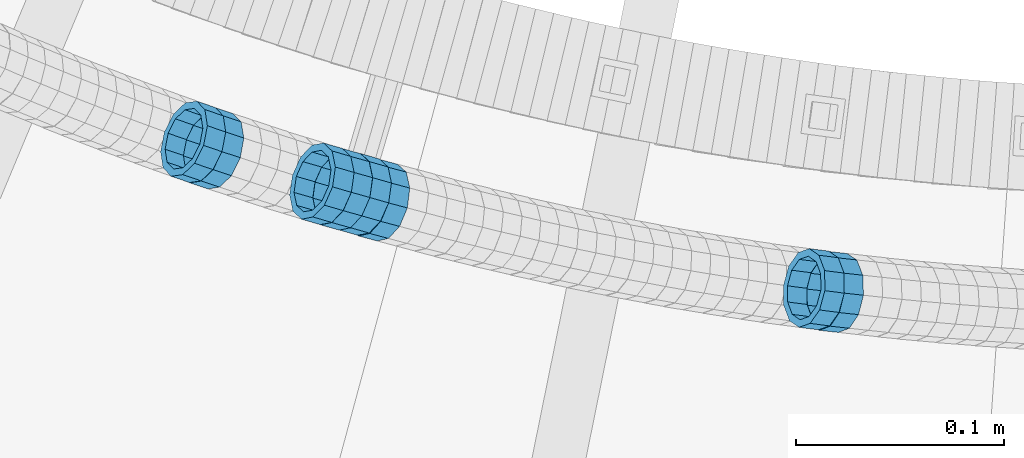
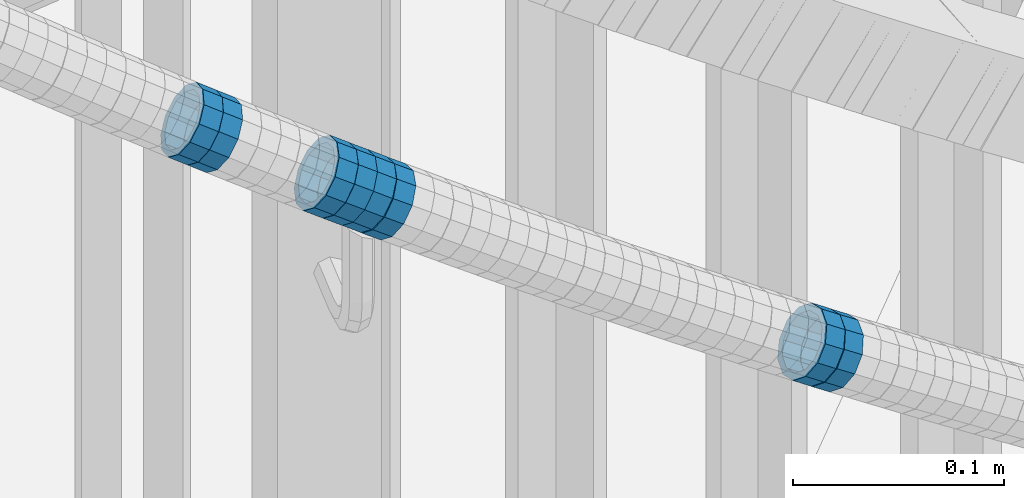
# One storey, part 688 of 975: 8 members.
"""IFC2X3 building model written with IfcOpenShell, lengths in millimetres."""

from ifc_helpers import new_model, si_unit, frame, origin_with_axes, place, context, subcontext, project, spatial, faceted_brep, material, type_object, element, save


model = new_model("IFC2X3")

# Units and contexts
model_context = context("Model", 3, precision=1e-05, world=origin_with_axes())
body_context = subcontext(model_context, "Body", "Model", "MODEL_VIEW")
ifc_project = project(units=[si_unit("LENGTHUNIT", "METRE", prefix="MILLI"), si_unit("AREAUNIT", "SQUARE_METRE"), si_unit("VOLUMEUNIT", "CUBIC_METRE"), si_unit("MASSUNIT", "GRAM", prefix="KILO"), si_unit("TIMEUNIT", "SECOND"), si_unit("PLANEANGLEUNIT", "RADIAN"), si_unit("SOLIDANGLEUNIT", "STERADIAN"), si_unit("THERMODYNAMICTEMPERATUREUNIT", "DEGREE_CELSIUS"), si_unit("LUMINOUSINTENSITYUNIT", "LUMEN")], contexts=[model_context])

# Site, building, storey
site_placement = place(None, origin_with_axes())
site = spatial("IfcSite", under=ifc_project, at=site_placement, CompositionType="ELEMENT")
building_placement = place(site_placement, origin_with_axes())
building = spatial("IfcBuilding", under=site, at=building_placement, Name="Undefined", CompositionType="ELEMENT")
storey_placement = place(building_placement, origin_with_axes())
storey = spatial("IfcBuildingStorey", under=building, at=storey_placement, Name="Undefined", CompositionType="ELEMENT", Elevation=0.0)

# Members
ifc_material = material()
member_type = type_object("IfcMemberType", PredefinedType="NOTDEFINED")
member_1_placement = place(storey_placement, frame((34258.5164340381, 2002.63154159642, 4505.87445303745), z_axis=(-0.312988116355664, -0.949757042100838, 1.91695107787382e-10), x_axis=(-0.808941078191672, 0.266582855063186, 0.523973199124206)))
element("IfcMember", 1, at=member_1_placement, inside=storey, type_object=member_type, material=ifc_material, Name="WALL", context=body_context, shape_type="Brep", body=[
    faceted_brep([(-2.1246523829177e-07, -15.367000000002, 0.0), (-1.83998054126278e-07, -13.3082123799541, 7.68350000000009), (10.8784190028109, -13.3082123799541, 7.68349999999555), (10.8784190028309, -15.3669999999929, 2.5465851649642e-11), (-1.06232619145885e-07, -7.68349999999919, 13.3082123799559), (10.8784190027873, -7.68350000000464, 13.308212379925), (-3.63797880709171e-12, 3.63797880709171e-12, 15.3670000000002), (10.8784190027782, -9.09494701772928e-12, 15.3669999999584), (1.06225343188271e-07, 7.68350000000646, 13.3082123799559), (10.8784190027691, 7.68349999998645, 13.3082123798995), (1.8399441614747e-07, 13.308212379965, 7.68350000000009), (10.8784190027764, 13.3082123799431, 7.68349999995553), (2.12461600312963e-07, 15.3670000000093, 0.0), (10.8784190027891, 15.3669999999929, -2.91038304567337e-11), (1.8399441614747e-07, 13.308212379965, -7.68350000000009), (10.8784190028055, 13.3082123799541, -7.68350000000646), (1.06225343188271e-07, 7.68350000000646, -13.3082123799559), (10.8784190028236, 7.68350000000464, -13.3082123799431), (-3.63797880709171e-12, 3.63797880709171e-12, -15.3670000000002), (10.87841900284, 1.2732925824821e-11, -15.366999999962), (-1.06232619145885e-07, -7.68349999999919, -13.3082123799559), (10.8784190028437, -7.68349999998463, -13.308212379914), (-1.83998054126278e-07, -13.3082123799541, -7.68350000000009), (10.8784190028437, -13.3082123799413, -7.68349999996281), (-2.63386027654633e-07, -19.0500000000029, 0.0), (-2.28097633225843e-07, -16.4977839420972, -9.52499999999964), (10.8784190028491, -16.4977839420771, -9.52499999995416), (10.8784190028346, -19.0499999999902, 2.91038304567337e-11), (-1.31691194837913e-07, -9.52500000000146, -16.4977839420935), (10.8784190028582, -9.52499999998145, -16.497783942039), (-3.63797880709171e-12, 3.63797880709171e-12, -19.0500000000002), (10.8784190028473, 1.63709046319127e-11, -19.0499999999556), (1.31687556859106e-07, 9.52500000000509, -16.4977839420935), (10.8784190028291, 9.52500000000691, -16.4977839420753), (2.28097633225843e-07, 16.4977839421044, -9.52499999999964), (10.8784190028073, 16.4977839420917, -9.52500000000509), (2.63382389675826e-07, 19.0500000000138, 0.0), (10.8784190027836, 19.0499999999884, -4.00177668780088e-11), (2.28097633225843e-07, 16.4977839421044, 9.52499999999964), (10.8784190027654, 16.4977839420771, 9.52499999994325), (1.31687556859106e-07, 9.52500000000509, 16.4977839420935), (10.8784190027636, 9.52499999998327, 16.4977839420317), (-3.63797880709171e-12, 3.63797880709171e-12, 19.0500000000002), (10.8784190027709, -1.63709046319127e-11, 19.0499999999447), (-1.31691194837913e-07, -9.52500000000146, 16.4977839420935), (10.8784190027854, -9.52500000000691, 16.4977839420644), (-2.28097633225843e-07, -16.4977839420972, 9.52499999999964), (10.8784190028091, -16.4977839420899, 9.52500000000146)], [[[0, 1, 2, 3]], [[1, 4, 5, 2]], [[4, 6, 7, 5]], [[6, 8, 9, 7]], [[8, 10, 11, 9]], [[10, 12, 13, 11]], [[12, 14, 15, 13]], [[14, 16, 17, 15]], [[16, 18, 19, 17]], [[18, 20, 21, 19]], [[20, 22, 23, 21]], [[22, 0, 3, 23]], [[24, 25, 26, 27]], [[25, 28, 29, 26]], [[28, 30, 31, 29]], [[30, 32, 33, 31]], [[32, 34, 35, 33]], [[34, 36, 37, 35]], [[36, 38, 39, 37]], [[38, 40, 41, 39]], [[40, 42, 43, 41]], [[42, 44, 45, 43]], [[44, 46, 47, 45]], [[46, 24, 27, 47]], [[29, 31, 33, 35, 37, 39, 41, 43, 45, 47, 27, 26], [5, 7, 9, 11, 13, 15, 17, 19, 21, 23, 3, 2]], [[46, 44, 42, 40, 38, 36, 34, 32, 30, 28, 25, 24], [22, 20, 18, 16, 14, 12, 10, 8, 6, 4, 1, 0]]]),
])
member_2_placement = place(storey_placement, frame((34249.7723069922, 2005.62022331465, 4511.55922879623), z_axis=(-0.322673927941658, -0.946510188126204, -5.88215698371641e-11), x_axis=(-0.806932045135231, 0.275090470046072, 0.522671893087532)))
element("IfcMember", 2, at=member_2_placement, inside=storey, type_object=member_type, material=ifc_material, Name="WALL", context=body_context, shape_type="Brep", body=[
    faceted_brep([(-2.1246523829177e-07, -15.367000000002, 0.0), (-1.83998054126278e-07, -13.3082123799541, 7.68350000000009), (10.9055031979988, -13.3082123799322, 7.68349999999873), (10.9055031979988, -15.3669999999729, -1.81898940354586e-12), (-1.06232619145885e-07, -7.68349999999919, 13.3082123799559), (10.9055031979842, -7.683499999981, 13.3082123799552), (-3.63797880709171e-12, 3.63797880709171e-12, 15.3670000000002), (10.9055031979697, 7.27595761418343e-12, 15.3670000000002), (1.06225343188271e-07, 7.68350000000646, 13.3082123799559), (10.9055031979478, 7.68349999999191, 13.3082123799561), (1.8399441614747e-07, 13.308212379965, 7.68350000000009), (10.9055031979333, 13.3082123799395, 7.68350000000078), (2.12461600312963e-07, 15.3670000000093, 0.0), (10.9055031979187, 15.3669999999802, 4.54747350886464e-13), (1.8399441614747e-07, 13.308212379965, -7.68350000000009), (10.9055031979187, 13.3082123799395, -7.68350000000009), (1.06225343188271e-07, 7.68350000000646, -13.3082123799559), (10.9055031979296, 7.68349999999191, -13.3082123799561), (-3.63797880709171e-12, 3.63797880709171e-12, -15.3670000000002), (10.9055031979478, 3.63797880709171e-12, -15.3670000000013), (-1.06232619145885e-07, -7.68349999999919, -13.3082123799559), (10.9055031979697, -7.683499999981, -13.3082123799575), (-1.83998054126278e-07, -13.3082123799541, -7.68350000000009), (10.9055031979842, -13.3082123799286, -7.68350000000214), (-2.63386027654633e-07, -19.0500000000029, 0.0), (-2.28097633225843e-07, -16.4977839420972, -9.52499999999964), (10.9055031979879, -16.4977839420681, -9.52500000000214), (10.9055031980097, -19.0499999999629, -2.04636307898909e-12), (-1.31691194837913e-07, -9.52500000000146, -16.4977839420935), (10.9055031979624, -9.52499999998327, -16.4977839420956), (-3.63797880709171e-12, 3.63797880709171e-12, -19.0500000000002), (10.9055031979406, 3.63797880709171e-12, -19.0500000000015), (1.31687556859106e-07, 9.52500000000509, -16.4977839420935), (10.9055031979151, 9.5249999999869, -16.4977839420942), (2.28097633225843e-07, 16.4977839421044, -9.52499999999964), (10.9055031979115, 16.4977839420717, -9.52499999999986), (2.63382389675826e-07, 19.0500000000138, 0.0), (10.9055031979115, 19.0499999999774, 6.82121026329696e-13), (2.28097633225843e-07, 16.4977839421044, 9.52499999999964), (10.9055031979296, 16.4977839420753, 9.52500000000123), (1.31687556859106e-07, 9.52500000000509, 16.4977839420935), (10.9055031979515, 9.52499999999054, 16.4977839420942), (-3.63797880709171e-12, 3.63797880709171e-12, 19.0500000000002), (10.9055031979733, 7.27595761418343e-12, 19.0500000000004), (-1.31691194837913e-07, -9.52500000000146, 16.4977839420935), (10.9055031979988, -9.52499999997599, 16.4977839420933), (-2.28097633225843e-07, -16.4977839420972, 9.52499999999964), (10.905503198006, -16.4977839420644, 9.52499999999873)], [[[0, 1, 2, 3]], [[1, 4, 5, 2]], [[4, 6, 7, 5]], [[6, 8, 9, 7]], [[8, 10, 11, 9]], [[10, 12, 13, 11]], [[12, 14, 15, 13]], [[14, 16, 17, 15]], [[16, 18, 19, 17]], [[18, 20, 21, 19]], [[20, 22, 23, 21]], [[22, 0, 3, 23]], [[24, 25, 26, 27]], [[25, 28, 29, 26]], [[28, 30, 31, 29]], [[30, 32, 33, 31]], [[32, 34, 35, 33]], [[34, 36, 37, 35]], [[36, 38, 39, 37]], [[38, 40, 41, 39]], [[40, 42, 43, 41]], [[42, 44, 45, 43]], [[44, 46, 47, 45]], [[46, 24, 27, 47]], [[29, 31, 33, 35, 37, 39, 41, 43, 45, 47, 27, 26], [5, 7, 9, 11, 13, 15, 17, 19, 21, 23, 3, 2]], [[46, 44, 42, 40, 38, 36, 34, 32, 30, 28, 25, 24], [22, 20, 18, 16, 14, 12, 10, 8, 6, 4, 1, 0]]]),
])
member_3_placement = place(storey_placement, frame((34557.1645562191, 1934.58696290878, 4316.57991200939), z_axis=(-0.108059180815137, -0.994144463064379, -1.17480340122711e-10), x_axis=(-0.846462505067043, 0.0920067940072997, 0.524438726041588)))
element("IfcMember", 3, at=member_3_placement, inside=storey, type_object=member_type, material=ifc_material, Name="WALL", context=body_context, shape_type="Brep", body=[
    faceted_brep([(-2.1246523829177e-07, -15.367000000002, 0.0), (-1.83998054126278e-07, -13.3082123799541, 7.68350000000009), (10.8747413762467, -13.3082123799468, 7.68349999999737), (10.8747413762612, -15.3669999999911, -4.54747350886464e-12), (-1.06232619145885e-07, -7.68349999999919, 13.3082123799559), (10.8747413762321, -7.68350000000282, 13.3082123799559), (-3.63797880709171e-12, 3.63797880709171e-12, 15.3670000000002), (10.8747413762212, -7.27595761418343e-12, 15.3670000000029), (1.06225343188271e-07, 7.68350000000646, 13.3082123799559), (10.8747413762139, 7.68349999998827, 13.3082123799586), (1.8399441614747e-07, 13.308212379965, 7.68350000000009), (10.8747413762212, 13.3082123799504, 7.683500000001), (2.12461600312963e-07, 15.3670000000093, 0.0), (10.8747413762285, 15.3669999999984, 9.09494701772928e-13), (1.8399441614747e-07, 13.308212379965, -7.68350000000009), (10.8747413762394, 13.3082123799613, -7.683500000001), (1.06225343188271e-07, 7.68350000000646, -13.3082123799559), (10.874741376254, 7.68350000001374, -13.3082123799604), (-3.63797880709171e-12, 3.63797880709171e-12, -15.3670000000002), (10.8747413762685, 1.81898940354586e-11, -15.3670000000056), (-1.06232619145885e-07, -7.68349999999919, -13.3082123799559), (10.8747413762758, -7.683499999981, -13.3082123799632), (-1.83998054126278e-07, -13.3082123799541, -7.68350000000009), (10.8747413762721, -13.3082123799359, -7.68350000000737), (-2.63386027654633e-07, -19.0500000000029, 0.0), (-2.28097633225843e-07, -16.4977839420972, -9.52499999999964), (10.8747413762867, -16.4977839420681, -9.52500000000873), (10.8747413762685, -19.0499999999847, -6.3664629124105e-12), (-1.31691194837913e-07, -9.52500000000146, -16.4977839420935), (10.8747413762831, -9.52499999997599, -16.4977839421026), (-3.63797880709171e-12, 3.63797880709171e-12, -19.0500000000002), (10.8747413762758, 2.5465851649642e-11, -19.0500000000084), (1.31687556859106e-07, 9.52500000000509, -16.4977839420935), (10.8747413762612, 9.52500000001601, -16.497783942099), (2.28097633225843e-07, 16.4977839421044, -9.52499999999964), (10.8747413762394, 16.4977839421008, -9.52500000000146), (2.63382389675826e-07, 19.0500000000138, 0.0), (10.8747413762248, 19.0499999999956, 0.0), (2.28097633225843e-07, 16.4977839421044, 9.52499999999964), (10.8747413762103, 16.497783942079, 9.52500000000418), (1.31687556859106e-07, 9.52500000000509, 16.4977839420935), (10.8747413762067, 9.52499999998327, 16.4977839420981), (-3.63797880709171e-12, 3.63797880709171e-12, 19.0500000000002), (10.8747413762212, -1.09139364212751e-11, 19.0500000000029), (-1.31691194837913e-07, -9.52500000000146, 16.4977839420935), (10.8747413762358, -9.52500000000146, 16.4977839420944), (-2.28097633225843e-07, -16.4977839420972, 9.52499999999964), (10.874741376254, -16.4977839420862, 9.524999999996)], [[[0, 1, 2, 3]], [[1, 4, 5, 2]], [[4, 6, 7, 5]], [[6, 8, 9, 7]], [[8, 10, 11, 9]], [[10, 12, 13, 11]], [[12, 14, 15, 13]], [[14, 16, 17, 15]], [[16, 18, 19, 17]], [[18, 20, 21, 19]], [[20, 22, 23, 21]], [[22, 0, 3, 23]], [[24, 25, 26, 27]], [[25, 28, 29, 26]], [[28, 30, 31, 29]], [[30, 32, 33, 31]], [[32, 34, 35, 33]], [[34, 36, 37, 35]], [[36, 38, 39, 37]], [[38, 40, 41, 39]], [[40, 42, 43, 41]], [[42, 44, 45, 43]], [[44, 46, 47, 45]], [[46, 24, 27, 47]], [[29, 31, 33, 35, 37, 39, 41, 43, 45, 47, 27, 26], [5, 7, 9, 11, 13, 15, 17, 19, 21, 23, 3, 2]], [[46, 44, 42, 40, 38, 36, 34, 32, 30, 28, 25, 24], [22, 20, 18, 16, 14, 12, 10, 8, 6, 4, 1, 0]]]),
])
member_4_placement = place(storey_placement, frame((34547.9580375468, 1935.78978836989, 4322.29868348133), z_axis=(-0.127971337933879, -0.99177786659484, -8.49195203045383e-12), x_axis=(-0.843470193525273, 0.108834863938749, 0.526035174704005)))
element("IfcMember", 4, at=member_4_placement, inside=storey, type_object=member_type, material=ifc_material, Name="WALL", context=body_context, shape_type="Brep", body=[
    faceted_brep([(-2.1246523829177e-07, -15.367000000002, 0.0), (-1.83998054126278e-07, -13.3082123799541, 7.68350000000009), (11.0295058819465, -13.3082123799577, 7.68350000000055), (11.0295058819393, -15.3670000000056, 0.0), (-1.06232619145885e-07, -7.68349999999919, 13.3082123799559), (11.0295058819502, -7.68350000000282, 13.3082123799563), (-3.63797880709171e-12, 3.63797880709171e-12, 15.3670000000002), (11.0295058819574, 0.0, 15.3670000000006), (1.06225343188271e-07, 7.68350000000646, 13.3082123799559), (11.0295058819647, 7.68350000000646, 13.3082123799559), (1.8399441614747e-07, 13.308212379965, 7.68350000000009), (11.0295058819756, 13.308212379965, 7.68349999999919), (2.12461600312963e-07, 15.3670000000093, 0.0), (11.029505881972, 15.3670000000056, -1.36424205265939e-12), (1.8399441614747e-07, 13.308212379965, -7.68350000000009), (11.0295058819684, 13.3082123799613, -7.683500000001), (1.06225343188271e-07, 7.68350000000646, -13.3082123799559), (11.0295058819574, 7.68350000000282, -13.3082123799563), (-3.63797880709171e-12, 3.63797880709171e-12, -15.3670000000002), (11.0295058819502, 0.0, -15.3670000000011), (-1.06232619145885e-07, -7.68349999999919, -13.3082123799559), (11.0295058819465, -7.68350000000282, -13.3082123799559), (-1.83998054126278e-07, -13.3082123799541, -7.68350000000009), (11.0295058819393, -13.3082123799613, -7.68350000000009), (-2.63386027654633e-07, -19.0500000000029, 0.0), (-2.28097633225843e-07, -16.4977839420972, -9.52499999999964), (11.0295058819356, -16.4977839421008, -9.52499999999964), (11.0295058819356, -19.0500000000102, 9.09494701772928e-13), (-1.31691194837913e-07, -9.52500000000146, -16.4977839420935), (11.0295058819393, -9.52500000000146, -16.497783942094), (-3.63797880709171e-12, 3.63797880709171e-12, -19.0500000000002), (11.0295058819429, 0.0, -19.0500000000015), (1.31687556859106e-07, 9.52500000000509, -16.4977839420935), (11.0295058819574, 9.52500000000146, -16.4977839420949), (2.28097633225843e-07, 16.4977839421044, -9.52499999999964), (11.029505881972, 16.4977839421044, -9.52500000000191), (2.63382389675826e-07, 19.0500000000138, 0.0), (11.0295058819793, 19.0500000000102, -4.54747350886464e-13), (2.28097633225843e-07, 16.4977839421044, 9.52499999999964), (11.0295058819793, 16.4977839421044, 9.52499999999918), (1.31687556859106e-07, 9.52500000000509, 16.4977839420935), (11.029505881972, 9.52500000000509, 16.4977839420935), (-3.63797880709171e-12, 3.63797880709171e-12, 19.0500000000002), (11.0295058819611, 0.0, 19.0500000000011), (-1.31691194837913e-07, -9.52500000000146, 16.4977839420935), (11.0295058819465, -9.52500000000509, 16.4977839420949), (-2.28097633225843e-07, -16.4977839420972, 9.52499999999964), (11.0295058819393, -16.4977839421008, 9.52500000000055)], [[[0, 1, 2, 3]], [[1, 4, 5, 2]], [[4, 6, 7, 5]], [[6, 8, 9, 7]], [[8, 10, 11, 9]], [[10, 12, 13, 11]], [[12, 14, 15, 13]], [[14, 16, 17, 15]], [[16, 18, 19, 17]], [[18, 20, 21, 19]], [[20, 22, 23, 21]], [[22, 0, 3, 23]], [[24, 25, 26, 27]], [[25, 28, 29, 26]], [[28, 30, 31, 29]], [[30, 32, 33, 31]], [[32, 34, 35, 33]], [[34, 36, 37, 35]], [[36, 38, 39, 37]], [[38, 40, 41, 39]], [[40, 42, 43, 41]], [[42, 44, 45, 43]], [[44, 46, 47, 45]], [[46, 24, 27, 47]], [[29, 31, 33, 35, 37, 39, 41, 43, 45, 47, 27, 26], [5, 7, 9, 11, 13, 15, 17, 19, 21, 23, 3, 2]], [[46, 44, 42, 40, 38, 36, 34, 32, 30, 28, 25, 24], [22, 20, 18, 16, 14, 12, 10, 8, 6, 4, 1, 0]]]),
])
member_5_placement = place(storey_placement, frame((34338.5888265773, 1977.96946803606, 4454.15104049631), z_axis=(-0.257662650594451, -0.966234939592148, -1.78564732777886e-10), x_axis=(-0.824163383850657, 0.219776901960162, 0.521970142905347)))
element("IfcMember", 5, at=member_5_placement, inside=storey, type_object=member_type, material=ifc_material, Name="WALL", context=body_context, shape_type="Brep", body=[
    faceted_brep([(-2.1246523829177e-07, -15.367000000002, 0.0), (-1.83998054126278e-07, -13.3082123799541, 7.68350000000009), (10.9242848735521, -13.3082123800159, 7.68350000000919), (10.9242848735703, -15.3670000000457, 6.82121026329696e-12), (-1.06232619145885e-07, -7.68349999999919, 13.3082123799559), (10.9242848735521, -7.68350000005739, 13.3082123799652), (-3.63797880709171e-12, 3.63797880709171e-12, 15.3670000000002), (10.924284873563, -4.72937244921923e-11, 15.3670000000088), (1.06225343188271e-07, 7.68350000000646, 13.3082123799559), (10.9242848735885, 7.68349999997008, 13.308212379962), (1.8399441614747e-07, 13.308212379965, 7.68350000000009), (10.9242848736176, 13.3082123799468, 7.68350000000328), (2.12461600312963e-07, 15.3670000000093, 0.0), (10.9242848736394, 15.3670000000093, 0.0), (1.8399441614747e-07, 13.308212379965, -7.68350000000009), (10.9242848736576, 13.3082123799795, -7.6835000000026), (1.06225343188271e-07, 7.68350000000646, -13.3082123799559), (10.9242848736576, 7.68350000002465, -13.3082123799584), (-3.63797880709171e-12, 3.63797880709171e-12, -15.3670000000002), (10.9242848736467, 1.45519152283669e-11, -15.3670000000025), (-1.06232619145885e-07, -7.68349999999919, -13.3082123799559), (10.9242848736212, -7.68350000000282, -13.3082123799552), (-1.83998054126278e-07, -13.3082123799541, -7.68350000000009), (10.9242848735958, -13.3082123799832, -7.68349999999646), (-2.63386027654633e-07, -19.0500000000029, 0.0), (-2.28097633225843e-07, -16.4977839420972, -9.52499999999964), (10.9242848735885, -16.4977839421226, -9.52499999999577), (10.9242848735557, -19.0500000000575, 8.18545231595635e-12), (-1.31691194837913e-07, -9.52500000000146, -16.4977839420935), (10.9242848736249, -9.52500000000146, -16.4977839420942), (-3.63797880709171e-12, 3.63797880709171e-12, -19.0500000000002), (10.924284873654, 2.18278728425503e-11, -19.0500000000038), (1.31687556859106e-07, 9.52500000000509, -16.4977839420935), (10.9242848736758, 9.52500000003783, -16.4977839420985), (2.28097633225843e-07, 16.4977839421044, -9.52499999999964), (10.9242848736758, 16.4977839421299, -9.52500000000418), (2.63382389675826e-07, 19.0500000000138, 0.0), (10.9242848736503, 19.0500000000211, -1.36424205265939e-12), (2.28097633225843e-07, 16.4977839421044, 9.52499999999964), (10.9242848736249, 16.4977839420899, 9.52500000000259), (1.31687556859106e-07, 9.52500000000509, 16.4977839420935), (10.9242848735885, 9.52499999996508, 16.4977839421008), (-3.63797880709171e-12, 3.63797880709171e-12, 19.0500000000002), (10.9242848735594, -5.82076609134674e-11, 19.0500000000104), (-1.31691194837913e-07, -9.52500000000146, 16.4977839420935), (10.9242848735375, -9.52500000007058, 16.4977839421056), (-2.28097633225843e-07, -16.4977839420972, 9.52499999999964), (10.9242848735412, -16.4977839421626, 9.52500000001078)], [[[0, 1, 2, 3]], [[1, 4, 5, 2]], [[4, 6, 7, 5]], [[6, 8, 9, 7]], [[8, 10, 11, 9]], [[10, 12, 13, 11]], [[12, 14, 15, 13]], [[14, 16, 17, 15]], [[16, 18, 19, 17]], [[18, 20, 21, 19]], [[20, 22, 23, 21]], [[22, 0, 3, 23]], [[24, 25, 26, 27]], [[25, 28, 29, 26]], [[28, 30, 31, 29]], [[30, 32, 33, 31]], [[32, 34, 35, 33]], [[34, 36, 37, 35]], [[36, 38, 39, 37]], [[38, 40, 41, 39]], [[40, 42, 43, 41]], [[42, 44, 45, 43]], [[44, 46, 47, 45]], [[46, 24, 27, 47]], [[29, 31, 33, 35, 37, 39, 41, 43, 45, 47, 27, 26], [5, 7, 9, 11, 13, 15, 17, 19, 21, 23, 3, 2]], [[46, 44, 42, 40, 38, 36, 34, 32, 30, 28, 25, 24], [22, 20, 18, 16, 14, 12, 10, 8, 6, 4, 1, 0]]]),
])
member_6_placement = place(storey_placement, frame((34329.5625874627, 1980.59055460896, 4459.90302386072), z_axis=(-0.277539653203669, -0.960714182730529, 1.67447979038116e-10), x_axis=(-0.81683279512389, 0.235973919035816, 0.526403357079884)))
element("IfcMember", 6, at=member_6_placement, inside=storey, type_object=member_type, material=ifc_material, Name="WALL", context=body_context, shape_type="Brep", body=[
    faceted_brep([(-2.1246523829177e-07, -15.367000000002, 0.0), (-1.83998054126278e-07, -13.3082123799541, 7.68350000000009), (11.0181668166479, -13.3082123799941, 7.68349999998463), (11.0181668166588, -15.3670000000275, -1.09139364212751e-11), (-1.06232619145885e-07, -7.68349999999919, 13.3082123799559), (11.0181668166369, -7.6835000000392, 13.3082123799377), (-3.63797880709171e-12, 3.63797880709171e-12, 15.3670000000002), (11.0181668166297, -4.00177668780088e-11, 15.3669999999784), (1.06225343188271e-07, 7.68350000000646, 13.3082123799559), (11.0181668166333, 7.68349999996644, 13.3082123799359), (1.8399441614747e-07, 13.308212379965, 7.68350000000009), (11.0181668166442, 13.3082123799286, 7.68349999998463), (2.12461600312963e-07, 15.3670000000093, 0.0), (11.0181668166588, 15.3669999999838, -9.09494701772928e-12), (1.8399441614747e-07, 13.308212379965, -7.68350000000009), (11.0181668166697, 13.3082123799504, -7.68350000000464), (1.06225343188271e-07, 7.68350000000646, -13.3082123799559), (11.0181668166806, 7.68349999999555, -13.3082123799577), (-3.63797880709171e-12, 3.63797880709171e-12, -15.3670000000002), (11.0181668166842, -7.27595761418343e-12, -15.367000000002), (-1.06232619145885e-07, -7.68349999999919, -13.3082123799559), (11.018166816677, -7.68350000001374, -13.3082123799595), (-1.83998054126278e-07, -13.3082123799541, -7.68350000000009), (11.0181668166661, -13.3082123799795, -7.68350000000646), (-2.63386027654633e-07, -19.0500000000029, 0.0), (-2.28097633225843e-07, -16.4977839420972, -9.52499999999964), (11.0181668166733, -16.4977839421153, -9.52500000000509), (11.0181668166588, -19.0500000000284, -1.2732925824821e-11), (-1.31691194837913e-07, -9.52500000000146, -16.4977839420935), (11.0181668166842, -9.52500000001237, -16.4977839420953), (-3.63797880709171e-12, 3.63797880709171e-12, -19.0500000000002), (11.0181668166915, -3.63797880709171e-12, -19.0500000000011), (1.31687556859106e-07, 9.52500000000509, -16.4977839420935), (11.0181668166879, 9.52499999999782, -16.4977839420935), (2.28097633225843e-07, 16.4977839421044, -9.52499999999964), (11.018166816677, 16.4977839420862, -9.52500000000691), (2.63382389675826e-07, 19.0500000000138, 0.0), (11.0181668166624, 19.0499999999884, -1.09139364212751e-11), (2.28097633225843e-07, 16.4977839421044, 9.52499999999964), (11.0181668166406, 16.4977839420644, 9.52499999998145), (1.31687556859106e-07, 9.52500000000509, 16.4977839420935), (11.0181668166297, 9.52499999996508, 16.4977839420717), (-3.63797880709171e-12, 3.63797880709171e-12, 19.0500000000002), (11.0181668166224, -4.00177668780088e-11, 19.0499999999738), (-1.31691194837913e-07, -9.52500000000146, 16.4977839420935), (11.0181668166297, -9.52500000004511, 16.4977839420735), (-2.28097633225843e-07, -16.4977839420972, 9.52499999999964), (11.0181668166406, -16.4977839421335, 9.52499999998327)], [[[0, 1, 2, 3]], [[1, 4, 5, 2]], [[4, 6, 7, 5]], [[6, 8, 9, 7]], [[8, 10, 11, 9]], [[10, 12, 13, 11]], [[12, 14, 15, 13]], [[14, 16, 17, 15]], [[16, 18, 19, 17]], [[18, 20, 21, 19]], [[20, 22, 23, 21]], [[22, 0, 3, 23]], [[24, 25, 26, 27]], [[25, 28, 29, 26]], [[28, 30, 31, 29]], [[30, 32, 33, 31]], [[32, 34, 35, 33]], [[34, 36, 37, 35]], [[36, 38, 39, 37]], [[38, 40, 41, 39]], [[40, 42, 43, 41]], [[42, 44, 45, 43]], [[44, 46, 47, 45]], [[46, 24, 27, 47]], [[29, 31, 33, 35, 37, 39, 41, 43, 45, 47, 27, 26], [5, 7, 9, 11, 13, 15, 17, 19, 21, 23, 3, 2]], [[46, 44, 42, 40, 38, 36, 34, 32, 30, 28, 25, 24], [22, 20, 18, 16, 14, 12, 10, 8, 6, 4, 1, 0]]]),
])
member_7_placement = place(storey_placement, frame((34320.5709780693, 1983.11122170574, 4465.68460807061), z_axis=(-0.270432301548208, -0.962738993850015, -2.43180693360045e-10), x_axis=(-0.819485047910005, 0.230192428974721, 0.524838738942406)))
element("IfcMember", 7, at=member_7_placement, inside=storey, type_object=member_type, material=ifc_material, Name="WALL", context=body_context, shape_type="Brep", body=[
    faceted_brep([(-2.1246523829177e-07, -15.367000000002, 0.0), (-1.83998054126278e-07, -13.3082123799541, 7.68350000000009), (10.8613995415399, -13.3082123799322, 7.68349999999191), (10.8613995415435, -15.3669999999729, -8.18545231595635e-12), (-1.06232619145885e-07, -7.68349999999919, 13.3082123799559), (10.8613995415217, -7.683499999981, 13.3082123799504), (-3.63797880709171e-12, 3.63797880709171e-12, 15.3670000000002), (10.8613995415071, 3.63797880709171e-12, 15.3669999999984), (1.06225343188271e-07, 7.68350000000646, 13.3082123799559), (10.861399541478, 7.68349999998463, 13.3082123799586), (1.8399441614747e-07, 13.308212379965, 7.68350000000009), (10.8613995414671, 13.3082123799322, 7.68350000000555), (2.12461600312963e-07, 15.3670000000093, 0.0), (10.8613995414562, 15.3669999999693, 7.27595761418343e-12), (1.8399441614747e-07, 13.308212379965, -7.68350000000009), (10.8613995414671, 13.3082123799322, -7.68349999999191), (1.06225343188271e-07, 7.68350000000646, -13.3082123799559), (10.861399541478, 7.683499999981, -13.3082123799513), (-3.63797880709171e-12, 3.63797880709171e-12, -15.3670000000002), (10.8613995415035, -3.63797880709171e-12, -15.3670000000002), (-1.06232619145885e-07, -7.68349999999919, -13.3082123799559), (10.8613995415253, -7.68349999998827, -13.3082123799586), (-1.83998054126278e-07, -13.3082123799541, -7.68350000000009), (10.8613995415435, -13.3082123799286, -7.68350000000828), (-2.63386027654633e-07, -19.0500000000029, 0.0), (-2.28097633225843e-07, -16.4977839420972, -9.52499999999964), (10.8613995415471, -16.4977839420717, -9.52500000000782), (10.8613995415581, -19.0499999999629, -1.09139364212751e-11), (-1.31691194837913e-07, -9.52500000000146, -16.4977839420935), (10.861399541529, -9.5249999999869, -16.4977839420972), (-3.63797880709171e-12, 3.63797880709171e-12, -19.0500000000002), (10.8613995415035, -7.27595761418343e-12, -19.0499999999984), (1.31687556859106e-07, 9.52500000000509, -16.4977839420935), (10.861399541478, 9.52499999997963, -16.497783942089), (2.28097633225843e-07, 16.4977839421044, -9.52499999999964), (10.8613995414526, 16.4977839420644, -9.52499999999236), (2.63382389675826e-07, 19.0500000000138, 0.0), (10.8613995414489, 19.0499999999665, 8.18545231595635e-12), (2.28097633225843e-07, 16.4977839421044, 9.52499999999964), (10.8613995414598, 16.4977839420644, 9.52500000000691), (1.31687556859106e-07, 9.52500000000509, 16.4977839420935), (10.8613995414744, 9.5249999999869, 16.4977839420972), (-3.63797880709171e-12, 3.63797880709171e-12, 19.0500000000002), (10.8613995414998, 3.63797880709171e-12, 19.0499999999993), (-1.31691194837913e-07, -9.52500000000146, 16.4977839420935), (10.861399541529, -9.52499999997599, 16.4977839420862), (-2.28097633225843e-07, -16.4977839420972, 9.52499999999964), (10.8613995415508, -16.4977839420644, 9.52499999999145)], [[[0, 1, 2, 3]], [[1, 4, 5, 2]], [[4, 6, 7, 5]], [[6, 8, 9, 7]], [[8, 10, 11, 9]], [[10, 12, 13, 11]], [[12, 14, 15, 13]], [[14, 16, 17, 15]], [[16, 18, 19, 17]], [[18, 20, 21, 19]], [[20, 22, 23, 21]], [[22, 0, 3, 23]], [[24, 25, 26, 27]], [[25, 28, 29, 26]], [[28, 30, 31, 29]], [[30, 32, 33, 31]], [[32, 34, 35, 33]], [[34, 36, 37, 35]], [[36, 38, 39, 37]], [[38, 40, 41, 39]], [[40, 42, 43, 41]], [[42, 44, 45, 43]], [[44, 46, 47, 45]], [[46, 24, 27, 47]], [[29, 31, 33, 35, 37, 39, 41, 43, 45, 47, 27, 26], [5, 7, 9, 11, 13, 15, 17, 19, 21, 23, 3, 2]], [[46, 44, 42, 40, 38, 36, 34, 32, 30, 28, 25, 24], [22, 20, 18, 16, 14, 12, 10, 8, 6, 4, 1, 0]]]),
])
member_8_placement = place(storey_placement, frame((34311.6625874627, 1985.69055460894, 4471.40302386075), z_axis=(-0.277539653203669, -0.960714182730529, 1.67447979038116e-10), x_axis=(-0.81683279512389, 0.235973919035816, 0.526403357079884)))
element("IfcMember", 8, at=member_8_placement, inside=storey, type_object=member_type, material=ifc_material, Name="WALL", context=body_context, shape_type="Brep", body=[
    faceted_brep([(-2.1246523829177e-07, -15.367000000002, 0.0), (-1.83998054126278e-07, -13.3082123799541, 7.68350000000009), (11.0181668166479, -13.3082123799941, 7.68349999998463), (11.0181668166588, -15.3670000000275, -1.09139364212751e-11), (-1.06232619145885e-07, -7.68349999999919, 13.3082123799559), (11.0181668166369, -7.6835000000392, 13.3082123799377), (-3.63797880709171e-12, 3.63797880709171e-12, 15.3670000000002), (11.0181668166297, -4.00177668780088e-11, 15.3669999999784), (1.06225343188271e-07, 7.68350000000646, 13.3082123799559), (11.0181668166333, 7.68349999996644, 13.3082123799359), (1.8399441614747e-07, 13.308212379965, 7.68350000000009), (11.0181668166442, 13.3082123799286, 7.68349999998463), (2.12461600312963e-07, 15.3670000000093, 0.0), (11.0181668166588, 15.3669999999838, -9.09494701772928e-12), (1.8399441614747e-07, 13.308212379965, -7.68350000000009), (11.0181668166697, 13.3082123799504, -7.68350000000464), (1.06225343188271e-07, 7.68350000000646, -13.3082123799559), (11.0181668166806, 7.68349999999555, -13.3082123799577), (-3.63797880709171e-12, 3.63797880709171e-12, -15.3670000000002), (11.0181668166842, -7.27595761418343e-12, -15.367000000002), (-1.06232619145885e-07, -7.68349999999919, -13.3082123799559), (11.018166816677, -7.68350000001374, -13.3082123799595), (-1.83998054126278e-07, -13.3082123799541, -7.68350000000009), (11.0181668166661, -13.3082123799795, -7.68350000000646), (-2.63386027654633e-07, -19.0500000000029, 0.0), (-2.28097633225843e-07, -16.4977839420972, -9.52499999999964), (11.0181668166733, -16.4977839421153, -9.52500000000509), (11.0181668166588, -19.0500000000284, -1.2732925824821e-11), (-1.31691194837913e-07, -9.52500000000146, -16.4977839420935), (11.0181668166842, -9.52500000001237, -16.4977839420953), (-3.63797880709171e-12, 3.63797880709171e-12, -19.0500000000002), (11.0181668166915, -3.63797880709171e-12, -19.0500000000011), (1.31687556859106e-07, 9.52500000000509, -16.4977839420935), (11.0181668166879, 9.52499999999782, -16.4977839420935), (2.28097633225843e-07, 16.4977839421044, -9.52499999999964), (11.018166816677, 16.4977839420862, -9.52500000000691), (2.63382389675826e-07, 19.0500000000138, 0.0), (11.0181668166624, 19.0499999999884, -1.09139364212751e-11), (2.28097633225843e-07, 16.4977839421044, 9.52499999999964), (11.0181668166406, 16.4977839420644, 9.52499999998145), (1.31687556859106e-07, 9.52500000000509, 16.4977839420935), (11.0181668166297, 9.52499999996508, 16.4977839420717), (-3.63797880709171e-12, 3.63797880709171e-12, 19.0500000000002), (11.0181668166224, -4.00177668780088e-11, 19.0499999999738), (-1.31691194837913e-07, -9.52500000000146, 16.4977839420935), (11.0181668166297, -9.52500000004511, 16.4977839420735), (-2.28097633225843e-07, -16.4977839420972, 9.52499999999964), (11.0181668166406, -16.4977839421335, 9.52499999998327)], [[[0, 1, 2, 3]], [[1, 4, 5, 2]], [[4, 6, 7, 5]], [[6, 8, 9, 7]], [[8, 10, 11, 9]], [[10, 12, 13, 11]], [[12, 14, 15, 13]], [[14, 16, 17, 15]], [[16, 18, 19, 17]], [[18, 20, 21, 19]], [[20, 22, 23, 21]], [[22, 0, 3, 23]], [[24, 25, 26, 27]], [[25, 28, 29, 26]], [[28, 30, 31, 29]], [[30, 32, 33, 31]], [[32, 34, 35, 33]], [[34, 36, 37, 35]], [[36, 38, 39, 37]], [[38, 40, 41, 39]], [[40, 42, 43, 41]], [[42, 44, 45, 43]], [[44, 46, 47, 45]], [[46, 24, 27, 47]], [[29, 31, 33, 35, 37, 39, 41, 43, 45, 47, 27, 26], [5, 7, 9, 11, 13, 15, 17, 19, 21, 23, 3, 2]], [[46, 44, 42, 40, 38, 36, 34, 32, 30, 28, 25, 24], [22, 20, 18, 16, 14, 12, 10, 8, 6, 4, 1, 0]]]),
])

save(model, "model.ifc")
